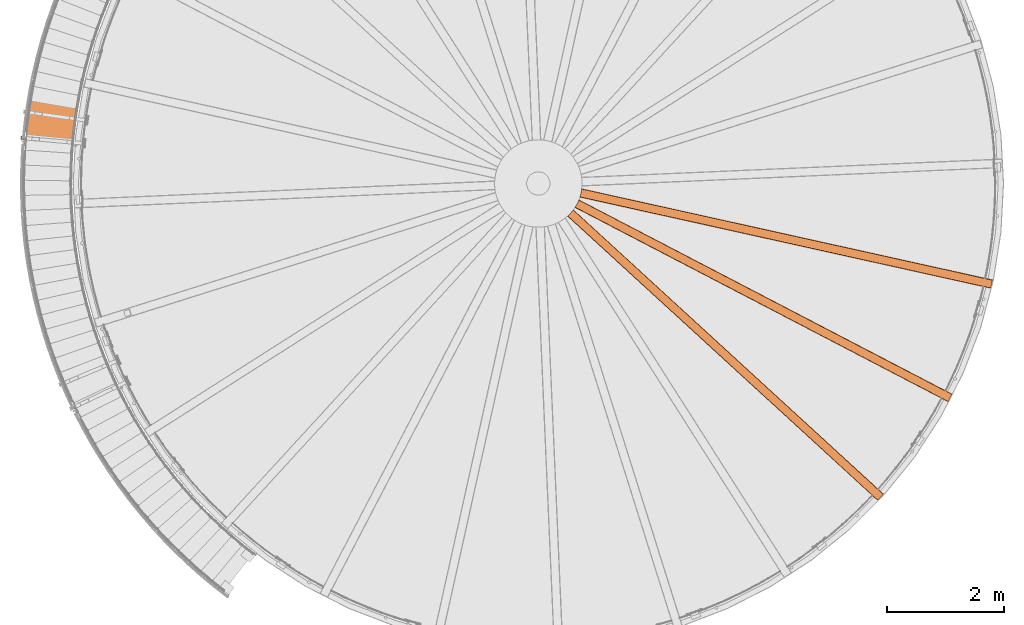
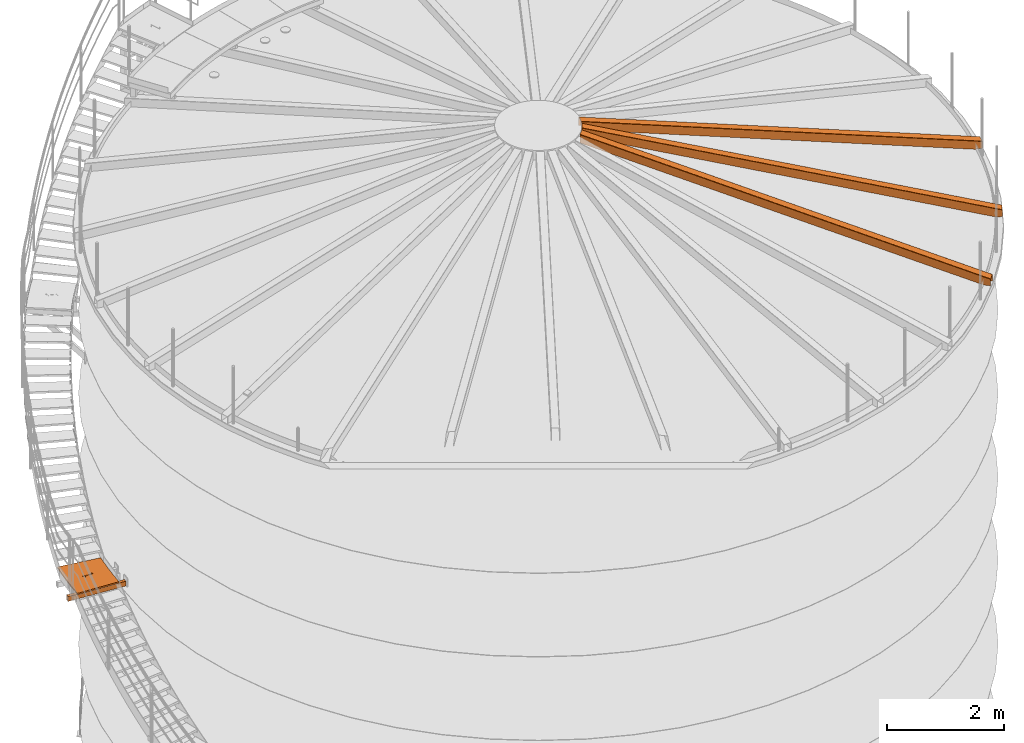
# One storey, part 22 of 126: 5 proxies.
"""IFC2X3 building model written with IfcOpenShell, lengths in millimetres."""

import ifcopenshell
import ifcopenshell.guid

model = None  # the IFC model being written
_history = None  # IfcOwnerHistory: only IFC2X3 demands one
_inside = {}  # id of a spatial element -> (the spatial element, [elements in it])
_under = {}  # id of a project, library or spatial element -> (it, [spatial elements below it])
_declared = {}  # id of a project -> (the project, [libraries it declares])
_typed = {}  # id of a type object -> (the type object, [elements of that type])
_made_of = {}  # id of a material, layer set ... -> (it, [elements and type objects made of it])


def new_model(schema):
    """Start an empty IFC model of exactly this schema.

    Asked for "IFC4X3", IfcOpenShell would pick the latest addendum, in which some entities
    have other attributes; the version numbers below select the first issue.
    IFC2X3 requires an IfcOwnerHistory on every rooted entity: one is made here for all.
    """
    global model, _history
    if schema == "IFC4X3":
        model = ifcopenshell.file(schema_version=(4, 3, 0, 0))
    else:
        model = ifcopenshell.file(schema=schema)
    _inside.clear()
    _under.clear()
    _declared.clear()
    _typed.clear()
    _made_of.clear()
    _history = None
    if model.schema == "IFC2X3":
        org = make("IfcOrganization", Name="unknown")
        user = make(
            "IfcPersonAndOrganization",
            ThePerson=make("IfcPerson", FamilyName="unknown"),
            TheOrganization=org,
        )
        app = make(
            "IfcApplication",
            ApplicationDeveloper=org,
            Version="unknown",
            ApplicationFullName="unknown",
            ApplicationIdentifier="unknown",
        )
        _history = make(
            "IfcOwnerHistory",
            OwningUser=user,
            OwningApplication=app,
            ChangeAction="ADDED",
            CreationDate=0,
        )
    return model


def make(cls, **values):
    """One entity of the class cls with the attributes given. An attribute that is None is left unset."""
    return model.create_entity(
        cls, **{name: value for name, value in values.items() if value is not None}
    )


def rooted(cls, **values):
    """An entity with a GlobalId (a new one), such as an element, a storey or a relation."""
    return make(cls, GlobalId=ifcopenshell.guid.new(), OwnerHistory=_history, **values)


def si_unit(unit_type, name, prefix=None):
    """IfcSIUnit, for example si_unit("LENGTHUNIT", "METRE", prefix="MILLI")."""
    return make("IfcSIUnit", UnitType=unit_type, Prefix=prefix, Name=name)


def assignment(units):
    """IfcUnitAssignment: the units of a project."""
    return None if units is None else make("IfcUnitAssignment", Units=units)


def point(xyz):
    """IfcCartesianPoint."""
    return None if xyz is None else make("IfcCartesianPoint", Coordinates=xyz)


def direction(xyz):
    """IfcDirection."""
    return None if xyz is None else make("IfcDirection", DirectionRatios=xyz)


def frame(location, z_axis=None, x_axis=None):
    """IfcAxis2Placement3D, a coordinate frame: its origin and axes. An axis left out is left unset."""
    return make(
        "IfcAxis2Placement3D",
        Location=point(location),
        Axis=direction(z_axis),
        RefDirection=direction(x_axis),
    )


def origin():
    """The frame at (0, 0, 0) with its axes left unset."""
    return frame((0.0, 0.0, 0.0))


def origin_with_axes():
    """The frame at (0, 0, 0) with the z axis (0, 0, 1) and the x axis (1, 0, 0) written out."""
    return frame((0.0, 0.0, 0.0), z_axis=(0.0, 0.0, 1.0), x_axis=(1.0, 0.0, 0.0))


def place(relative_to, where):
    """IfcLocalPlacement: puts the frame where relative to a parent placement (None: the world)."""
    return make(
        "IfcLocalPlacement", PlacementRelTo=relative_to, RelativePlacement=where
    )


def context(
    kind, dimensions, precision=None, world=None, true_north=None, identifier=None
):
    """IfcGeometricRepresentationContext, for example the 3D "Model" context."""
    return make(
        "IfcGeometricRepresentationContext",
        ContextIdentifier=identifier,
        ContextType=kind,
        CoordinateSpaceDimension=dimensions,
        Precision=precision,
        WorldCoordinateSystem=world,
        TrueNorth=true_north,
    )


def project(units=None, contexts=None):
    """IfcProject with its units and contexts."""
    return rooted(
        "IfcProject",
        Name="project",
        RepresentationContexts=contexts,
        UnitsInContext=assignment(units),
    )


def spatial(cls, under=None, at=None, **own):
    """A site, building, storey or space (cls), placed at a placement, below another one or the project."""
    s = rooted(cls, ObjectPlacement=at, **own)
    if under is not None:
        _under.setdefault(under.id(), (under, []))[1].append(s)
    return s


def faces_of(points, faces, orient=None, outer=None):
    """IfcFace entities. A face is a list of loops; a loop is a list of indices into points, from 0.

    orient and outer hold one flag for each loop. By default every Orientation is true, the
    first loop of a face is its IfcFaceOuterBound and the others are IfcFaceBound.
    """
    made = []
    for i, loops in enumerate(faces):
        bounds = []
        for j, loop in enumerate(loops):
            is_outer = j == 0 if outer is None else outer[i][j]
            bounds.append(
                make(
                    "IfcFaceOuterBound" if is_outer else "IfcFaceBound",
                    Bound=make("IfcPolyLoop", Polygon=[points[k] for k in loop]),
                    Orientation=True if orient is None else orient[i][j],
                )
            )
        made.append(make("IfcFace", Bounds=bounds))
    return made


def faceted_brep(points, faces, orient=None, outer=None, voids=None):
    """IfcFacetedBrep: a solid bounded by flat faces; with voids (closed shells), ...WithVoids."""
    shared = [point(p) for p in points]
    hull = make("IfcClosedShell", CfsFaces=faces_of(shared, faces, orient, outer))
    if voids is None:
        return make("IfcFacetedBrep", Outer=hull)
    return make(
        "IfcFacetedBrepWithVoids",
        Outer=hull,
        Voids=[
            make(cls, CfsFaces=faces_of(shared, fs, o, b)) for cls, fs, o, b in voids
        ],
    )


def shape(context_of_items, identifier, shape_type, items):
    """IfcShapeRepresentation: the items that make up one representation, for example the "Body"."""
    return make(
        "IfcShapeRepresentation",
        ContextOfItems=context_of_items,
        RepresentationIdentifier=identifier,
        RepresentationType=shape_type,
        Items=items,
    )


def material(Name=None, Category=None):
    """IfcMaterial."""
    return make("IfcMaterial", Name=Name, Category=Category)


def made_of(thing, what):
    """Note that an element or type object is made of a material, layer set ...; save() writes the relation."""
    if what is not None:
        _made_of.setdefault(what.id(), (what, []))[1].append(thing)
    return thing


def element(
    cls,
    number,
    at=None,
    inside=None,
    cuts=None,
    type_object=None,
    material=None,
    context=None,
    identifier="Body",
    shape_type=None,
    held_by="IfcProductDefinitionShape",
    body=None,
    shapes=None,
    **own,
):
    """One element of the class cls, such as IfcWall. Its Tag is "e" and its number.

    at: its placement. inside: the storey or other place that contains it. cuts: it is an
    opening in that element (IfcRelVoidsElement). A single representation is given by context,
    identifier, shape_type and body (its items); several are given by shapes. held_by: the class
    of the entity that holds the representations. save() writes the other relations.
    """
    e = rooted(cls, Tag="e%d" % number, ObjectPlacement=at, **own)
    if body is not None:
        shapes = [shape(context, identifier, shape_type, body)]
    if shapes is not None:
        e.Representation = make(held_by, Representations=shapes)
    if inside is not None:
        _inside.setdefault(inside.id(), (inside, []))[1].append(e)
    if cuts is not None:
        rooted(
            "IfcRelVoidsElement", RelatingBuildingElement=cuts, RelatedOpeningElement=e
        )
    if type_object is not None:
        _typed.setdefault(type_object.id(), (type_object, []))[1].append(e)
    return made_of(e, material)


def aggregate(whole, parts):
    """IfcRelAggregates: a whole, such as a stair, and the parts it consists of."""
    return rooted("IfcRelAggregates", RelatingObject=whole, RelatedObjects=parts)


def save(model, path):
    """Write the relations noted so far, then the file.

    IfcRelAggregates (storeys below a building ...), IfcRelContainedInSpatialStructure (elements
    in a storey), IfcRelDefinesByType, IfcRelAssociatesMaterial and IfcRelDeclares: one each for
    every whole, place, type object, material and project.
    """
    for whole, parts in _under.values():
        aggregate(whole, parts)
    for where, things in _inside.values():
        rooted(
            "IfcRelContainedInSpatialStructure",
            RelatedElements=things,
            RelatingStructure=where,
        )
    for kind, things in _typed.values():
        rooted("IfcRelDefinesByType", RelatedObjects=things, RelatingType=kind)
    for what, things in _made_of.values():
        rooted("IfcRelAssociatesMaterial", RelatedObjects=things, RelatingMaterial=what)
    for by, libraries in _declared.values():
        rooted("IfcRelDeclares", RelatingContext=by, RelatedDefinitions=libraries)
    model.write(path)


model = new_model("IFC2X3")

# Units and contexts
context_of_model_1 = context(None, 3, precision=0.1, world=origin())
context_of_model_2 = context(None, 3, precision=0.1, world=origin())
ifc_project = project(units=[si_unit("LENGTHUNIT", "METRE", prefix="MILLI"), si_unit("AREAUNIT", "SQUARE_METRE", prefix="CENTI"), si_unit("VOLUMEUNIT", "CUBIC_METRE", prefix="CENTI"), si_unit("MASSUNIT", "GRAM", prefix="KILO")], contexts=[context_of_model_1, context_of_model_2])

# Site, building, storey
site_placement = place(None, origin_with_axes())
site = spatial("IfcSite", under=ifc_project, at=site_placement, CompositionType="ELEMENT")
building_placement = place(site_placement, origin_with_axes())
building = spatial("IfcBuilding", under=site, at=building_placement, CompositionType="ELEMENT")
storey_placement = place(building_placement, origin_with_axes())
storey = spatial("IfcBuildingStorey", under=building, at=storey_placement, CompositionType="ELEMENT")

# Proxies
ifc_material_1 = material(Name="S235JRG2")
proxy_1_placement = place(storey_placement, origin_with_axes())
element("IfcBuildingElementProxy", 1, at=proxy_1_placement, inside=storey, material=ifc_material_1, Name="BLECH", context=context_of_model_2, shape_type="Brep", body=[
    faceted_brep([(-790.4294, 8576.8545, 5512.55), (-789.8682, 8585.4857, 5512.55), (-788.7119, 8602.7462, 5512.55), (-787.5218, 8620.0045, 5512.55), (-786.2978, 8637.2601, 5512.55), (-785.0399, 8654.5136, 5512.55), (-783.7482, 8671.7643, 5512.55), (-782.4226, 8689.0124, 5512.55), (-781.0631, 8706.2583, 5512.55), (-779.6698, 8723.501, 5512.55), (-778.2427, 8740.7411, 5512.55), (-776.7817, 8757.9784, 5512.55), (-775.287, 8775.2126, 5512.55), (-773.7583, 8792.4442, 5512.55), (-772.1959, 8809.6726, 5512.55), (-770.5997, 8826.8978, 5512.55), (-768.9696, 8844.1199, 5512.55), (-767.3058, 8861.3388, 5512.55), (-765.6081, 8878.5545, 5512.55), (-763.8767, 8895.7667, 5512.55), (-762.1115, 8912.9757, 5512.55), (-760.3125, 8930.181, 5512.55), (-758.4798, 8947.3828, 5512.55), (-756.6133, 8964.5809, 5512.55), (-754.713, 8981.7753, 5512.55), (-752.779, 8998.9657, 5512.55), (-750.8113, 9016.1529, 5512.55), (-748.8099, 9033.3355, 5512.55), (-746.7747, 9050.5145, 5512.55), (-744.7058, 9067.6894, 5512.55), (-742.6032, 9084.8602, 5512.55), (-740.4669, 9102.0269, 5512.55), (-738.2969, 9119.1895, 5512.55), (-736.0933, 9136.3476, 5512.55), (-733.8559, 9153.5015, 5512.55), (-731.5849, 9170.6508, 5512.55), (-729.2803, 9187.7956, 5512.55), (-726.942, 9204.9363, 5512.55), (-724.5701, 9222.0719, 5512.55), (-722.1645, 9239.2029, 5512.55), (-719.7253, 9256.3294, 5512.55), (-717.2525, 9273.4508, 5512.55), (-714.7462, 9290.5671, 5512.55), (-712.2062, 9307.6789, 5512.55), (-709.6326, 9324.7852, 5512.55), (-707.0255, 9341.8868, 5512.55), (-704.3848, 9358.9835, 5512.55), (-701.7106, 9376.0746, 5512.55), (-699.0028, 9393.1602, 5512.55), (-696.2615, 9410.2407, 5512.55), (-693.4867, 9427.3157, 5512.55), (-692.0825, 9435.8509, 5512.55), (90.6066, 9302.1658, 5512.55), (89.3414, 9294.4468, 5512.55), (86.8411, 9279.0044, 5512.55), (84.3709, 9263.5567, 5512.55), (81.9309, 9248.1047, 5512.55), (79.521, 9232.6474, 5512.55), (77.1413, 9217.1861, 5512.55), (74.7917, 9201.7196, 5512.55), (72.4723, 9186.2487, 5512.55), (70.1831, 9170.7735, 5512.55), (67.9241, 9155.2939, 5512.55), (65.6953, 9139.8095, 5512.55), (63.4967, 9124.3213, 5512.55), (61.3283, 9108.8286, 5512.55), (59.1901, 9093.3316, 5512.55), (57.0822, 9077.8308, 5512.55), (55.0045, 9062.3255, 5512.55), (52.957, 9046.8164, 5512.55), (50.9398, 9031.3035, 5512.55), (48.9529, 9015.7861, 5512.55), (46.9962, 9000.2654, 5512.55), (45.0698, 8984.7408, 5512.55), (43.1737, 8969.2123, 5512.55), (41.3079, 8953.6804, 5512.55), (39.4724, 8938.1446, 5512.55), (37.6672, 8922.6054, 5512.55), (35.8924, 8907.0628, 5512.55), (34.1478, 8891.5168, 5512.55), (32.4336, 8875.9674, 5512.55), (30.7497, 8860.4146, 5512.55), (29.0961, 8844.8584, 5512.55), (27.4729, 8829.2992, 5512.55), (25.88, 8813.7367, 5512.55), (24.3175, 8798.1712, 5512.55), (22.7854, 8782.6028, 5512.55), (21.2836, 8767.0315, 5512.55), (19.8122, 8751.4567, 5512.55), (18.3712, 8735.8795, 5512.55), (16.9606, 8720.2999, 5512.55), (15.5804, 8704.7173, 5512.55), (14.2305, 8689.1318, 5512.55), (12.9111, 8673.5438, 5512.55), (11.6221, 8657.9534, 5512.55), (10.3635, 8642.3605, 5512.55), (9.1353, 8626.7647, 5512.55), (7.9375, 8611.1669, 5512.55), (6.7702, 8595.5671, 5512.55), (5.6333, 8579.9644, 5512.55), (4.5268, 8564.3602, 5512.55), (3.4508, 8548.7535, 5512.55), (2.4052, 8533.1449, 5512.55), (1.8976, 8525.3393, 5512.55), (-790.4294, 8576.8545, 5542.55), (1.8976, 8525.3393, 5542.55), (2.4052, 8533.1449, 5542.55), (3.4508, 8548.7535, 5542.55), (4.5268, 8564.3602, 5542.55), (5.6333, 8579.9644, 5542.55), (6.7702, 8595.5671, 5542.55), (7.9375, 8611.1669, 5542.55), (9.1353, 8626.7647, 5542.55), (10.3635, 8642.3605, 5542.55), (11.6221, 8657.9534, 5542.55), (12.9111, 8673.5438, 5542.55), (14.2305, 8689.1318, 5542.55), (15.5804, 8704.7173, 5542.55), (16.9606, 8720.2999, 5542.55), (18.3712, 8735.8795, 5542.55), (19.8122, 8751.4567, 5542.55), (21.2836, 8767.0315, 5542.55), (22.7854, 8782.6028, 5542.55), (24.3175, 8798.1712, 5542.55), (25.88, 8813.7367, 5542.55), (27.4729, 8829.2992, 5542.55), (29.0961, 8844.8584, 5542.55), (30.7497, 8860.4146, 5542.55), (32.4336, 8875.9674, 5542.55), (34.1478, 8891.5168, 5542.55), (35.8924, 8907.0628, 5542.55), (37.6672, 8922.6054, 5542.55), (39.4724, 8938.1446, 5542.55), (41.3079, 8953.6804, 5542.55), (43.1737, 8969.2123, 5542.55), (45.0698, 8984.7408, 5542.55), (46.9962, 9000.2654, 5542.55), (48.9529, 9015.7861, 5542.55), (50.9398, 9031.3035, 5542.55), (52.957, 9046.8164, 5542.55), (55.0045, 9062.3255, 5542.55), (57.0822, 9077.8308, 5542.55), (59.1901, 9093.3316, 5542.55), (61.3283, 9108.8286, 5542.55), (63.4967, 9124.3213, 5542.55), (65.6953, 9139.8095, 5542.55), (67.9241, 9155.2939, 5542.55), (70.1831, 9170.7735, 5542.55), (72.4723, 9186.2487, 5542.55), (74.7917, 9201.7196, 5542.55), (77.1413, 9217.1861, 5542.55), (79.521, 9232.6474, 5542.55), (81.9309, 9248.1047, 5542.55), (84.3709, 9263.5567, 5542.55), (86.8411, 9279.0044, 5542.55), (89.3414, 9294.4468, 5542.55), (90.6066, 9302.1658, 5542.55), (-692.0825, 9435.8509, 5542.55), (-693.4867, 9427.3157, 5542.55), (-696.2615, 9410.2407, 5542.55), (-699.0028, 9393.1602, 5542.55), (-701.7106, 9376.0746, 5542.55), (-704.3848, 9358.9835, 5542.55), (-707.0255, 9341.8868, 5542.55), (-709.6326, 9324.7852, 5542.55), (-712.2062, 9307.6789, 5542.55), (-714.7462, 9290.5671, 5542.55), (-717.2525, 9273.4508, 5542.55), (-719.7253, 9256.3294, 5542.55), (-722.1645, 9239.2029, 5542.55), (-724.5701, 9222.0719, 5542.55), (-726.942, 9204.9363, 5542.55), (-729.2803, 9187.7956, 5542.55), (-731.5849, 9170.6508, 5542.55), (-733.8559, 9153.5015, 5542.55), (-736.0933, 9136.3476, 5542.55), (-738.2969, 9119.1895, 5542.55), (-740.4669, 9102.0269, 5542.55), (-742.6032, 9084.8602, 5542.55), (-744.7058, 9067.6894, 5542.55), (-746.7747, 9050.5145, 5542.55), (-748.8099, 9033.3355, 5542.55), (-750.8113, 9016.1529, 5542.55), (-752.779, 8998.9657, 5542.55), (-754.713, 8981.7753, 5542.55), (-756.6133, 8964.5809, 5542.55), (-758.4798, 8947.3828, 5542.55), (-760.3125, 8930.181, 5542.55), (-762.1115, 8912.9757, 5542.55), (-763.8767, 8895.7667, 5542.55), (-765.6081, 8878.5545, 5542.55), (-767.3058, 8861.3388, 5542.55), (-768.9696, 8844.1199, 5542.55), (-770.5997, 8826.8978, 5542.55), (-772.1959, 8809.6726, 5542.55), (-773.7583, 8792.4442, 5542.55), (-775.287, 8775.2126, 5542.55), (-776.7817, 8757.9784, 5542.55), (-778.2427, 8740.7411, 5542.55), (-779.6698, 8723.501, 5542.55), (-781.0631, 8706.2583, 5542.55), (-782.4226, 8689.0124, 5542.55), (-783.7482, 8671.7643, 5542.55), (-785.0399, 8654.5136, 5542.55), (-786.2978, 8637.2601, 5542.55), (-787.5218, 8620.0045, 5542.55), (-788.7119, 8602.7462, 5542.55), (-789.8682, 8585.4857, 5542.55), (-303.2086, 9002.2085, 5542.55), (-297.9482, 9006.8267, 5542.55), (-244.6545, 8946.1211, 5542.55), (-443.3631, 8968.8124, 5542.55), (-402.036, 8921.7377, 5542.55), (-407.2965, 8917.1195, 5542.55), (-460.5901, 8977.8251, 5542.55), (-261.8816, 8955.1338, 5542.55), (-303.2086, 9002.2085, 5537.55), (-297.9482, 9006.8267, 5537.55), (-261.8816, 8955.1338, 5537.55), (-244.6545, 8946.1211, 5537.55), (-460.5901, 8977.8251, 5537.55), (-443.3631, 8968.8124, 5537.55), (-407.2965, 8917.1195, 5537.55), (-402.036, 8921.7377, 5537.55)], [[[0, 1, 2, 3, 4, 5, 6, 7, 8, 9, 10, 11, 12, 13, 14, 15, 16, 17, 18, 19, 20, 21, 22, 23, 24, 25, 26, 27, 28, 29, 30, 31, 32, 33, 34, 35, 36, 37, 38, 39, 40, 41, 42, 43, 44, 45, 46, 47, 48, 49, 50, 51, 52, 53, 54, 55, 56, 57, 58, 59, 60, 61, 62, 63, 64, 65, 66, 67, 68, 69, 70, 71, 72, 73, 74, 75, 76, 77, 78, 79, 80, 81, 82, 83, 84, 85, 86, 87, 88, 89, 90, 91, 92, 93, 94, 95, 96, 97, 98, 99, 100, 101, 102, 103]], [[104, 105, 106, 107, 108, 109, 110, 111, 112, 113, 114, 115, 116, 117, 118, 119, 120, 121, 122, 123, 124, 125, 126, 127, 128, 129, 130, 131, 132, 133, 134, 135, 136, 137, 138, 139, 140, 141, 142, 143, 144, 145, 146, 147, 148, 149, 150, 151, 152, 153, 154, 155, 156, 157, 158, 159, 160, 161, 162, 163, 164, 165, 166, 167, 168, 169, 170, 171, 172, 173, 174, 175, 176, 177, 178, 179, 180, 181, 182, 183, 184, 185, 186, 187, 188, 189, 190, 191, 192, 193, 194, 195, 196, 197, 198, 199, 200, 201, 202, 203, 204, 205, 206, 207], [208, 209, 210, 211, 212, 213, 214, 215]], [[0, 104, 207, 1]], [[1, 207, 206, 2]], [[2, 206, 205, 3]], [[3, 205, 204, 4]], [[4, 204, 203, 5]], [[5, 203, 202, 6]], [[6, 202, 201, 7]], [[7, 201, 200, 8]], [[8, 200, 199, 9]], [[9, 199, 198, 10]], [[10, 198, 197, 11]], [[11, 197, 196, 12]], [[12, 196, 195, 13]], [[13, 195, 194, 14]], [[14, 194, 193, 15]], [[15, 193, 192, 16]], [[16, 192, 191, 17]], [[17, 191, 190, 18]], [[18, 190, 189, 19]], [[19, 189, 188, 20]], [[20, 188, 187, 21]], [[21, 187, 186, 22]], [[22, 186, 185, 23]], [[23, 185, 184, 24]], [[24, 184, 183, 25]], [[25, 183, 182, 26]], [[26, 182, 181, 27]], [[27, 181, 180, 28]], [[28, 180, 179, 29]], [[29, 179, 178, 30]], [[30, 178, 177, 31]], [[31, 177, 176, 32]], [[32, 176, 175, 33]], [[33, 175, 174, 34]], [[34, 174, 173, 35]], [[35, 173, 172, 36]], [[36, 172, 171, 37]], [[37, 171, 170, 38]], [[38, 170, 169, 39]], [[39, 169, 168, 40]], [[40, 168, 167, 41]], [[41, 167, 166, 42]], [[42, 166, 165, 43]], [[43, 165, 164, 44]], [[44, 164, 163, 45]], [[45, 163, 162, 46]], [[46, 162, 161, 47]], [[47, 161, 160, 48]], [[48, 160, 159, 49]], [[49, 159, 158, 50]], [[50, 158, 157, 51]], [[51, 157, 156, 52]], [[52, 156, 155, 53]], [[53, 155, 154, 54]], [[54, 154, 153, 55]], [[55, 153, 152, 56]], [[56, 152, 151, 57]], [[57, 151, 150, 58]], [[58, 150, 149, 59]], [[59, 149, 148, 60]], [[60, 148, 147, 61]], [[61, 147, 146, 62]], [[62, 146, 145, 63]], [[63, 145, 144, 64]], [[64, 144, 143, 65]], [[65, 143, 142, 66]], [[66, 142, 141, 67]], [[67, 141, 140, 68]], [[68, 140, 139, 69]], [[69, 139, 138, 70]], [[70, 138, 137, 71]], [[71, 137, 136, 72]], [[72, 136, 135, 73]], [[73, 135, 134, 74]], [[74, 134, 133, 75]], [[75, 133, 132, 76]], [[76, 132, 131, 77]], [[77, 131, 130, 78]], [[78, 130, 129, 79]], [[79, 129, 128, 80]], [[80, 128, 127, 81]], [[81, 127, 126, 82]], [[82, 126, 125, 83]], [[83, 125, 124, 84]], [[84, 124, 123, 85]], [[85, 123, 122, 86]], [[86, 122, 121, 87]], [[87, 121, 120, 88]], [[88, 120, 119, 89]], [[89, 119, 118, 90]], [[90, 118, 117, 91]], [[91, 117, 116, 92]], [[92, 116, 115, 93]], [[93, 115, 114, 94]], [[94, 114, 113, 95]], [[95, 113, 112, 96]], [[96, 112, 111, 97]], [[97, 111, 110, 98]], [[98, 110, 109, 99]], [[99, 109, 108, 100]], [[100, 108, 107, 101]], [[101, 107, 106, 102]], [[102, 106, 105, 103]], [[0, 103, 105, 104]], [[208, 216, 217, 209]], [[216, 218, 219, 217]], [[208, 215, 218, 216]], [[209, 217, 219, 210]], [[219, 218, 220, 221]], [[214, 220, 218, 215]], [[210, 219, 221, 211]], [[221, 220, 222, 223]], [[213, 222, 220, 214]], [[211, 221, 223, 212]], [[212, 223, 222, 213]]]),
])
proxy_2_placement = place(storey_placement, origin_with_axes())
element("IfcBuildingElementProxy", 2, at=proxy_2_placement, inside=storey, material=ifc_material_1, context=context_of_model_2, shape_type="Brep", body=[
    faceted_brep([(-870.802, 8758.4403, 5292.55), (-870.802, 8758.4403, 5392.55), (-865.5257, 8818.2078, 5392.55), (-865.5257, 8818.2078, 5292.55), (-870.5382, 8761.4286, 5295.55), (-865.7895, 8815.2194, 5295.55), (-865.7895, 8815.2194, 5389.55), (-870.5382, 8761.4286, 5389.55), (224.9063, 8721.9443, 5292.55), (219.63, 8662.1768, 5292.55), (224.9063, 8721.9443, 5392.55), (219.63, 8662.1768, 5392.55), (219.8938, 8665.1652, 5389.55), (219.8938, 8665.1652, 5295.55), (224.6424, 8718.956, 5389.55), (224.6424, 8718.956, 5295.55)], [[[0, 1, 2, 3], [4, 5, 6, 7]], [[0, 3, 8, 9]], [[2, 10, 8, 3]], [[1, 11, 10, 2]], [[0, 9, 11, 1]], [[4, 7, 12, 13]], [[6, 14, 12, 7]], [[5, 15, 14, 6]], [[4, 13, 15, 5]], [[9, 8, 10, 11], [12, 14, 15, 13]]]),
])
ifc_material_2 = material(Name="STAHL")
proxy_3_placement = place(storey_placement, origin_with_axes())
element("IfcBuildingElementProxy", 3, at=proxy_3_placement, inside=storey, material=ifc_material_2, Name="profile", context=context_of_model_2, shape_type="Brep", body=[
    faceted_brep([(8503.8, 7444.9, 12406.3), (8503.8, 7444.9, 12574.0), (8503.9, 7445.0, 12575.4), (8504.1, 7445.2, 12576.8), (8504.6, 7445.7, 12578.2), (8505.3, 7446.3, 12579.5), (8506.1, 7447.0, 12580.5), (8507.1, 7447.9, 12581.3), (8508.4, 7449.0, 12581.9), (8509.7, 7450.3, 12582.1), (8558.0, 7498.3, 12581.2), (8600.4, 7548.9, 12582.0), (8600.9, 7549.6, 12582.0), (8601.5, 7550.4, 12581.8), (8602.5, 7551.7, 12581.3), (8603.4, 7552.8, 12580.4), (8604.1, 7553.8, 12579.2), (8604.7, 7554.6, 12577.8), (8605.1, 7555.1, 12576.0), (8605.3, 7555.3, 12573.9), (8605.3, 7555.3, 12406.2), (8602.8, 7552.1, 12406.1), (8602.8, 7552.1, 12573.8), (8602.8, 7552.1, 12574.5), (8602.7, 7551.9, 12575.2), (8602.5, 7551.7, 12576.0), (8602.2, 7551.3, 12576.6), (8601.9, 7550.9, 12577.1), (8601.5, 7550.3, 12577.5), (8601.0, 7549.7, 12577.8), (8600.4, 7548.9, 12577.9), (8558.0, 7498.3, 12577.1), (8509.7, 7450.3, 12577.9), (8509.4, 7450.0, 12577.9), (8509.1, 7449.7, 12577.8), (8508.5, 7449.1, 12577.6), (8507.9, 7448.6, 12577.1), (8507.5, 7448.2, 12576.5), (8507.1, 7447.9, 12575.8), (8506.9, 7447.7, 12574.9), (8506.8, 7447.6, 12573.9), (8506.8, 7447.6, 12406.2), (13822.4, 2571.3, 10641.0), (13822.4, 2571.3, 10506.0), (13825.1, 2574.2, 10506.0), (13825.1, 2574.2, 10641.0), (13825.1, 2574.3, 10641.8), (13825.3, 2574.4, 10642.6), (13825.6, 2574.8, 10643.5), (13826.0, 2575.3, 10644.2), (13826.6, 2575.8, 10644.7), (13827.2, 2576.5, 10645.1), (13827.8, 2577.2, 10645.2), (13918.3, 2676.0, 10645.2), (13918.8, 2676.5, 10645.1), (13919.4, 2677.1, 10644.9), (13919.9, 2677.7, 10644.4), (13920.4, 2678.2, 10643.7), (13920.7, 2678.6, 10642.9), (13920.9, 2678.8, 10642.0), (13921.0, 2678.9, 10641.0), (13921.0, 2678.9, 10506.0), (13923.7, 2681.9, 10506.0), (13923.7, 2681.9, 10641.0), (13923.6, 2681.7, 10642.6), (13923.3, 2681.4, 10644.2), (13922.7, 2680.7, 10645.9), (13921.8, 2679.8, 10647.3), (13920.8, 2678.6, 10648.4), (13919.6, 2677.3, 10649.1), (13918.3, 2676.0, 10649.3), (13827.8, 2577.2, 10649.3), (13826.7, 2576.0, 10649.2), (13825.7, 2574.9, 10648.7), (13824.6, 2573.7, 10647.7), (13823.7, 2572.7, 10646.4), (13823.0, 2571.9, 10644.8), (13822.5, 2571.4, 10643.0), (13735.2, 2656.6, 10506.0), (13732.5, 2653.7, 10506.0), (13833.8, 2764.3, 10506.0), (13831.1, 2761.3, 10506.0)], [[[0, 1, 2, 3, 4, 5, 6, 7, 8, 9, 10, 11, 12, 13, 14, 15, 16, 17, 18, 19, 20, 21, 22, 23, 24, 25, 26, 27, 28, 29, 30, 31, 32, 33, 34, 35, 36, 37, 38, 39, 40, 41]], [[42, 43, 44, 45, 46, 47, 48, 49, 50, 51, 52, 53, 54, 55, 56, 57, 58, 59, 60, 61, 62, 63, 64, 65, 66, 67, 68, 69, 70, 71, 72, 73, 74, 75, 76, 77]], [[41, 78, 79, 0]], [[42, 77, 2, 1, 0, 79, 43]], [[77, 76, 75, 5, 4, 3, 2]], [[5, 75, 74, 6]], [[7, 6, 74, 73]], [[8, 7, 73, 72]], [[72, 71, 70, 69, 13, 12, 11, 10, 9, 8]], [[14, 13, 69, 68]], [[15, 14, 68, 67]], [[16, 15, 67, 66]], [[66, 65, 64, 18, 17, 16]], [[64, 63, 62, 80, 20, 19, 18]], [[21, 20, 80, 81]], [[61, 81, 80, 62]], [[44, 43, 79, 78]], [[45, 44, 78, 41, 40, 39, 46]], [[46, 39, 38, 37, 48, 47]], [[37, 36, 49, 48]], [[36, 35, 50, 49]], [[35, 34, 51, 50]], [[51, 34, 33, 32, 31, 30, 29, 54, 53, 52]], [[29, 28, 55, 54]], [[28, 27, 56, 55]], [[26, 57, 56, 27]], [[57, 26, 25, 24, 23, 59, 58]], [[59, 23, 22, 21, 81, 61, 60]]]),
])
proxy_4_placement = place(storey_placement, origin_with_axes())
element("IfcBuildingElementProxy", 4, at=proxy_4_placement, inside=storey, material=ifc_material_2, Name="profile", context=context_of_model_2, shape_type="Brep", body=[
    faceted_brep([(8631.7, 7593.1, 12574.0), (8631.8, 7593.2, 12575.4), (8632.0, 7593.5, 12576.8), (8632.4, 7594.0, 12578.2), (8632.9, 7594.8, 12579.5), (8633.5, 7595.7, 12580.5), (8634.2, 7596.8, 12581.3), (8635.1, 7598.2, 12581.9), (8636.1, 7599.8, 12582.1), (8670.3, 7658.7, 12581.2), (8698.2, 7718.6, 12582.0), (8698.5, 7719.4, 12582.0), (8698.8, 7720.2, 12581.8), (8699.5, 7721.8, 12581.3), (8700.0, 7723.1, 12580.4), (8700.5, 7724.2, 12579.2), (8700.8, 7725.1, 12577.8), (8701.1, 7725.8, 12576.0), (8701.2, 7726.0, 12573.9), (8701.2, 7726.0, 12406.2), (8699.7, 7722.3, 12406.1), (8699.7, 7722.3, 12573.8), (8699.7, 7722.2, 12574.5), (8699.6, 7722.1, 12575.2), (8699.5, 7721.8, 12576.0), (8699.3, 7721.3, 12576.6), (8699.1, 7720.8, 12577.1), (8698.8, 7720.2, 12577.5), (8698.5, 7719.4, 12577.8), (8698.2, 7718.6, 12577.9), (8670.3, 7658.7, 12577.1), (8636.1, 7599.8, 12577.9), (8635.9, 7599.4, 12577.9), (8635.6, 7599.0, 12577.8), (8635.2, 7598.4, 12577.6), (8634.8, 7597.7, 12577.1), (8634.5, 7597.2, 12576.5), (8634.2, 7596.8, 12575.8), (8634.0, 7596.5, 12574.9), (8633.9, 7596.4, 12573.9), (8633.9, 7596.4, 12406.2), (8631.7, 7593.1, 12406.3), (15030.5, 4262.1, 10641.0), (15030.5, 4262.1, 10506.0), (15032.4, 4265.6, 10506.0), (15032.4, 4265.6, 10641.0), (15032.4, 4265.7, 10641.8), (15032.5, 4265.9, 10642.6), (15032.7, 4266.3, 10643.5), (15033.0, 4266.9, 10644.2), (15033.4, 4267.6, 10644.7), (15033.8, 4268.3, 10645.1), (15034.2, 4269.2, 10645.2), (15096.1, 4388.0, 10645.2), (15096.4, 4388.7, 10645.1), (15096.8, 4389.4, 10644.9), (15097.2, 4390.1, 10644.4), (15097.5, 4390.7, 10643.7), (15097.7, 4391.2, 10642.9), (15097.9, 4391.5, 10642.0), (15097.9, 4391.6, 10641.0), (15097.9, 4391.6, 10506.0), (15099.8, 4395.1, 10506.0), (15099.8, 4395.1, 10641.0), (15099.7, 4395.0, 10642.6), (15099.5, 4394.6, 10644.2), (15099.1, 4393.8, 10645.9), (15098.5, 4392.6, 10647.3), (15097.8, 4391.2, 10648.4), (15096.9, 4389.7, 10649.1), (15096.1, 4388.0, 10649.3), (15034.2, 4269.2, 10649.3), (15033.5, 4267.8, 10649.2), (15032.8, 4266.4, 10648.7), (15032.0, 4265.0, 10647.7), (15031.4, 4263.8, 10646.4), (15030.9, 4262.8, 10644.8), (15030.6, 4262.3, 10643.0), (14924.2, 4321.9, 10506.0), (14922.3, 4318.4, 10506.0), (14991.6, 4451.4, 10506.0), (14989.7, 4447.9, 10506.0)], [[[0, 1, 2, 3, 4, 5, 6, 7, 8, 9, 10, 11, 12, 13, 14, 15, 16, 17, 18, 19, 20, 21, 22, 23, 24, 25, 26, 27, 28, 29, 30, 31, 32, 33, 34, 35, 36, 37, 38, 39, 40, 41]], [[42, 43, 44, 45, 46, 47, 48, 49, 50, 51, 52, 53, 54, 55, 56, 57, 58, 59, 60, 61, 62, 63, 64, 65, 66, 67, 68, 69, 70, 71, 72, 73, 74, 75, 76, 77]], [[40, 78, 79, 41]], [[42, 77, 1, 0, 41, 79, 43]], [[77, 76, 3, 2, 1]], [[3, 76, 75, 4]], [[4, 75, 74, 5]], [[6, 5, 74, 73]], [[7, 6, 73, 72]], [[72, 71, 70, 69, 12, 11, 10, 9, 8, 7]], [[13, 12, 69, 68]], [[14, 13, 68, 67]], [[15, 14, 67, 66]], [[16, 15, 66, 65]], [[17, 16, 65, 64]], [[64, 63, 62, 80, 19, 18, 17]], [[20, 19, 80, 81]], [[61, 81, 80, 62]], [[44, 43, 79, 78]], [[45, 44, 78, 40, 39, 38, 46]], [[38, 37, 47, 46]], [[37, 36, 48, 47]], [[36, 35, 49, 48]], [[35, 34, 50, 49]], [[34, 33, 51, 50]], [[51, 33, 32, 31, 30, 29, 28, 54, 53, 52]], [[28, 27, 55, 54]], [[27, 26, 56, 55]], [[25, 57, 56, 26]], [[24, 58, 57, 25]], [[58, 24, 23, 22, 59]], [[59, 22, 21, 20, 81, 61, 60]]]),
])
proxy_5_placement = place(storey_placement, origin_with_axes())
element("IfcBuildingElementProxy", 5, at=proxy_5_placement, inside=storey, material=ifc_material_2, Name="profile", context=context_of_model_2, shape_type="Brep", body=[
    faceted_brep([(8717.0, 7769.3, 12406.3), (8717.0, 7769.3, 12574.0), (8717.0, 7769.4, 12575.4), (8717.2, 7769.8, 12576.8), (8717.4, 7770.4, 12578.2), (8717.7, 7771.3, 12579.5), (8718.0, 7772.3, 12580.5), (8718.4, 7773.6, 12581.3), (8718.9, 7775.2, 12581.9), (8719.5, 7777.0, 12582.1), (8737.2, 7842.7, 12581.2), (8748.7, 7907.7, 12582.0), (8748.8, 7908.6, 12582.0), (8748.9, 7909.5, 12581.8), (8749.1, 7911.1, 12581.3), (8749.3, 7912.6, 12580.4), (8749.4, 7913.8, 12579.2), (8749.6, 7914.8, 12577.8), (8749.6, 7915.5, 12576.0), (8749.7, 7915.7, 12573.9), (8749.7, 7915.7, 12406.2), (8749.2, 7911.7, 12406.1), (8749.2, 7911.7, 12573.8), (8749.2, 7911.7, 12574.5), (8749.1, 7911.5, 12575.2), (8749.1, 7911.1, 12576.0), (8749.0, 7910.7, 12576.6), (8749.0, 7910.1, 12577.1), (8748.9, 7909.5, 12577.5), (8748.8, 7908.7, 12577.8), (8748.7, 7907.7, 12577.9), (8737.2, 7842.7, 12577.1), (8719.5, 7777.0, 12577.9), (8719.4, 7776.5, 12577.9), (8719.2, 7776.1, 12577.8), (8719.0, 7775.3, 12577.6), (8718.7, 7774.6, 12577.1), (8718.6, 7774.0, 12576.5), (8718.4, 7773.6, 12575.8), (8718.3, 7773.3, 12574.9), (8718.3, 7773.1, 12573.9), (8718.3, 7773.1, 12406.2), (15759.9, 6207.9, 10641.0), (15759.9, 6207.9, 10506.0), (15760.7, 6211.8, 10506.0), (15760.7, 6211.8, 10641.0), (15760.7, 6211.9, 10641.8), (15760.8, 6212.1, 10642.6), (15760.9, 6212.6, 10643.5), (15761.0, 6213.2, 10644.2), (15761.2, 6214.0, 10644.7), (15761.4, 6214.8, 10645.1), (15761.6, 6215.8, 10645.2), (15790.6, 6346.6, 10645.2), (15790.8, 6347.3, 10645.1), (15790.9, 6348.1, 10644.9), (15791.1, 6348.9, 10644.4), (15791.3, 6349.5, 10643.7), (15791.4, 6350.1, 10642.9), (15791.4, 6350.4, 10642.0), (15791.5, 6350.5, 10641.0), (15791.5, 6350.5, 10506.0), (15792.3, 6354.4, 10506.0), (15792.3, 6354.4, 10641.0), (15792.3, 6354.2, 10642.6), (15792.2, 6353.8, 10644.2), (15792.0, 6352.9, 10645.9), (15791.7, 6351.6, 10647.3), (15791.4, 6350.1, 10648.4), (15791.0, 6348.4, 10649.1), (15790.6, 6346.6, 10649.3), (15761.6, 6215.8, 10649.3), (15761.3, 6214.2, 10649.2), (15760.9, 6212.8, 10648.7), (15760.6, 6211.2, 10647.7), (15760.3, 6209.8, 10646.4), (15760.1, 6208.8, 10644.8), (15759.9, 6208.2, 10643.0), (15641.6, 6238.2, 10506.0), (15640.8, 6234.3, 10506.0), (15673.2, 6380.8, 10506.0), (15672.4, 6376.9, 10506.0)], [[[0, 1, 2, 3, 4, 5, 6, 7, 8, 9, 10, 11, 12, 13, 14, 15, 16, 17, 18, 19, 20, 21, 22, 23, 24, 25, 26, 27, 28, 29, 30, 31, 32, 33, 34, 35, 36, 37, 38, 39, 40, 41]], [[42, 43, 44, 45, 46, 47, 48, 49, 50, 51, 52, 53, 54, 55, 56, 57, 58, 59, 60, 61, 62, 63, 64, 65, 66, 67, 68, 69, 70, 71, 72, 73, 74, 75, 76, 77]], [[41, 78, 79, 0]], [[42, 77, 2, 1, 0, 79, 43]], [[77, 76, 4, 3, 2]], [[4, 76, 75, 5]], [[5, 75, 74, 6]], [[7, 6, 74, 73]], [[8, 7, 73, 72]], [[72, 71, 70, 69, 13, 12, 11, 10, 9, 8]], [[14, 13, 69, 68]], [[15, 14, 68, 67]], [[16, 15, 67, 66]], [[17, 16, 66, 65]], [[18, 17, 65, 64]], [[64, 63, 62, 80, 20, 19, 18]], [[21, 20, 80, 81]], [[61, 81, 80, 62]], [[44, 43, 79, 78]], [[45, 44, 78, 41, 40, 39, 46]], [[39, 38, 47, 46]], [[38, 37, 48, 47]], [[37, 36, 49, 48]], [[36, 35, 50, 49]], [[35, 34, 51, 50]], [[51, 34, 33, 32, 31, 30, 29, 54, 53, 52]], [[29, 28, 55, 54]], [[28, 27, 56, 55]], [[26, 57, 56, 27]], [[25, 58, 57, 26]], [[58, 25, 24, 23, 59]], [[59, 23, 22, 21, 81, 61, 60]]]),
])

save(model, "model.ifc")
